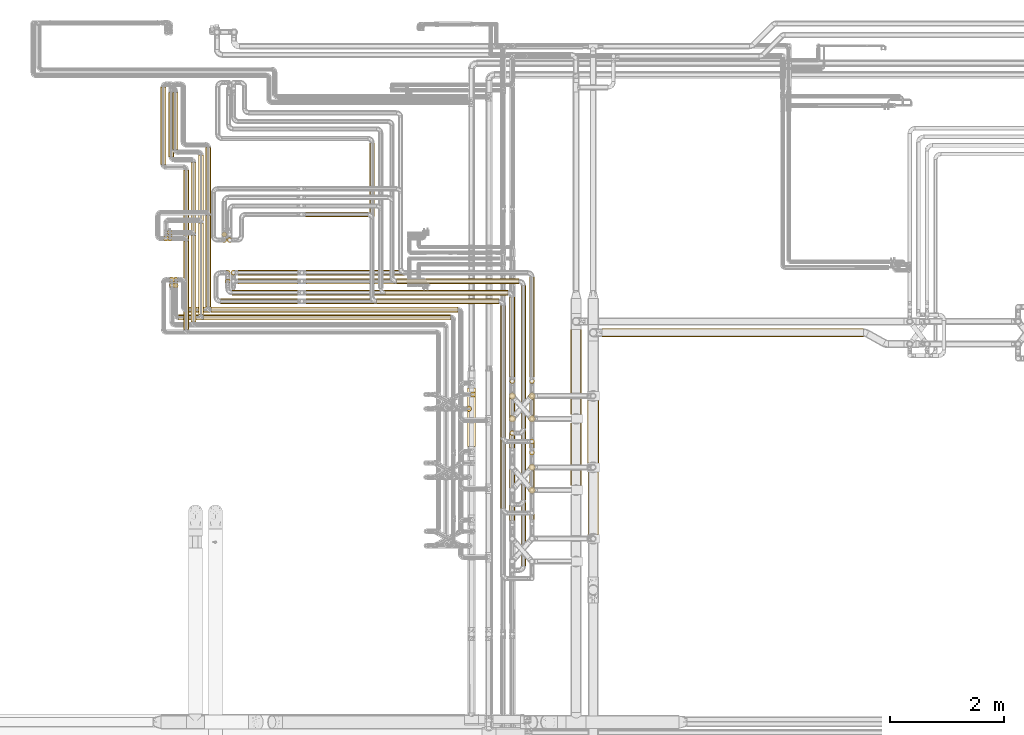
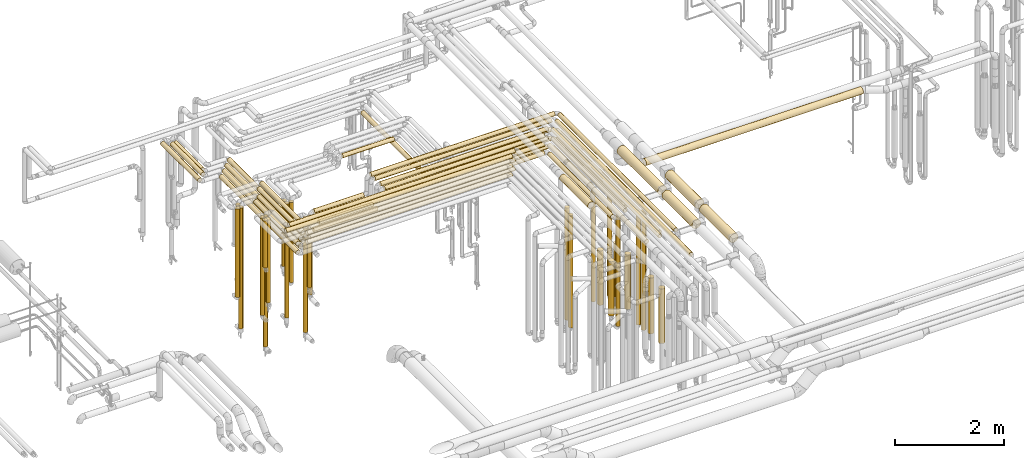
# One storey, part 5 of 824: 76 coverings.
"""IFC2X3 building model written with IfcOpenShell, lengths in millimetres."""

from ifc_helpers import new_model, entity, si_unit, converted_unit, derived_unit, direction, frame, origin, origin_2d_with_axis, place, context, subcontext, project, spatial, polyline, circle, outline, extrude, element, save


model = new_model("IFC2X3")

# Units and contexts
model_context = context("Model", 3, precision=0.01, world=origin(), true_north=direction((6.12303176911189e-17, 1.0)))
body_context = subcontext(model_context, "Body", "Model", "MODEL_VIEW")
ifc_project = project(units=[si_unit("LENGTHUNIT", "METRE", prefix="MILLI"), si_unit("AREAUNIT", "SQUARE_METRE"), si_unit("VOLUMEUNIT", "CUBIC_METRE"), converted_unit("PLANEANGLEUNIT", "DEGREE", entity("IfcRatioMeasure", 0.0174532925199433), si_unit("PLANEANGLEUNIT", "RADIAN"), dimensions=[0, 0, 0, 0, 0, 0, 0]), si_unit("MASSUNIT", "GRAM", prefix="KILO"), derived_unit("MASSDENSITYUNIT", [(si_unit("MASSUNIT", "GRAM", prefix="KILO"), 1), (si_unit("LENGTHUNIT", "METRE"), -3)]), derived_unit("MOMENTOFINERTIAUNIT", [(si_unit("LENGTHUNIT", "METRE"), 4)]), si_unit("TIMEUNIT", "SECOND"), si_unit("FREQUENCYUNIT", "HERTZ"), si_unit("THERMODYNAMICTEMPERATUREUNIT", "DEGREE_CELSIUS"), derived_unit("THERMALTRANSMITTANCEUNIT", [(si_unit("MASSUNIT", "GRAM", prefix="KILO"), 1), (si_unit("THERMODYNAMICTEMPERATUREUNIT", "KELVIN"), -1), (si_unit("TIMEUNIT", "SECOND"), -3)]), derived_unit("VOLUMETRICFLOWRATEUNIT", [(si_unit("LENGTHUNIT", "METRE"), 3), (si_unit("TIMEUNIT", "SECOND"), -1)]), derived_unit("MASSFLOWRATEUNIT", [(si_unit("MASSUNIT", "GRAM", prefix="KILO"), 1), (si_unit("TIMEUNIT", "SECOND"), -1)]), derived_unit("ROTATIONALFREQUENCYUNIT", [(si_unit("TIMEUNIT", "SECOND"), -1)]), si_unit("ELECTRICCURRENTUNIT", "AMPERE"), si_unit("ELECTRICVOLTAGEUNIT", "VOLT"), si_unit("POWERUNIT", "WATT"), si_unit("FORCEUNIT", "NEWTON", prefix="KILO"), si_unit("ILLUMINANCEUNIT", "LUX"), si_unit("LUMINOUSFLUXUNIT", "LUMEN"), si_unit("LUMINOUSINTENSITYUNIT", "CANDELA"), derived_unit("USERDEFINED", [(si_unit("MASSUNIT", "GRAM", prefix="KILO"), -1), (si_unit("LENGTHUNIT", "METRE"), -2), (si_unit("TIMEUNIT", "SECOND"), 3), (si_unit("LUMINOUSFLUXUNIT", "LUMEN"), 1)]), derived_unit("LINEARVELOCITYUNIT", [(si_unit("LENGTHUNIT", "METRE"), 1), (si_unit("TIMEUNIT", "SECOND"), -1)]), si_unit("PRESSUREUNIT", "PASCAL"), derived_unit("USERDEFINED", [(si_unit("LENGTHUNIT", "METRE"), -2), (si_unit("MASSUNIT", "GRAM", prefix="KILO"), 1), (si_unit("TIMEUNIT", "SECOND"), -2)]), derived_unit("LINEARFORCEUNIT", [(si_unit("MASSUNIT", "GRAM", prefix="KILO"), 1), (si_unit("LENGTHUNIT", "METRE"), 1), (si_unit("TIMEUNIT", "SECOND"), -2), (si_unit("LENGTHUNIT", "METRE"), -1)]), derived_unit("PLANARFORCEUNIT", [(si_unit("MASSUNIT", "GRAM", prefix="KILO"), 1), (si_unit("LENGTHUNIT", "METRE"), 1), (si_unit("TIMEUNIT", "SECOND"), -2), (si_unit("LENGTHUNIT", "METRE"), -2)])], contexts=[model_context])

# Site, building, storey
site_placement = place(None, origin())
site = spatial("IfcSite", under=ifc_project, at=site_placement, CompositionType="ELEMENT")
building_placement = place(site_placement, origin())
building = spatial("IfcBuilding", under=site, at=building_placement, CompositionType="ELEMENT")
storey_placement = place(building_placement, frame((0.0, 0.0, 28200.0)))
storey = spatial("IfcBuildingStorey", under=building, at=storey_placement, CompositionType="ELEMENT", Elevation=28200.0)

# Coverings
covering_1_placement = place(storey_placement, frame((31258.78, 14538.0, 3152.25)))
element("IfcCovering", 1, at=covering_1_placement, inside=storey, PredefinedType="INSULATION", context=body_context, shape_type="SweptSolid", body=[
    extrude(circle(Radius=46.15, at=origin_2d_with_axis()), frame((47.75, 0.0, 47.75), z_axis=(0.0, 1.0, 0.0), x_axis=(-1.0, 0.0, 0.0)), (0.0, 0.0, 1.0), 1605.20292594585),
])
covering_2_placement = place(storey_placement, frame((31128.78, 14408.0, 3152.25)))
element("IfcCovering", 2, at=covering_2_placement, inside=storey, PredefinedType="INSULATION", context=body_context, shape_type="SweptSolid", body=[
    extrude(circle(Radius=46.15, at=origin_2d_with_axis()), frame((47.75, 0.0, 47.75), z_axis=(0.0, 1.0, 0.0), x_axis=(-1.0, 0.0, 0.0)), (0.0, 0.0, 1.0), 1605.20292594584),
])
covering_3_placement = place(storey_placement, frame((31354.52, 14442.26, 3152.25)))
element("IfcCovering", 3, at=covering_3_placement, inside=storey, PredefinedType="INSULATION", context=body_context, shape_type="SweptSolid", body=[
    extrude(circle(Radius=46.15, at=origin_2d_with_axis()), frame((0.0, 47.75, 47.75), z_axis=(1.0, 0.0, 0.0), x_axis=(0.0, -1.0, 0.0)), (0.0, 0.0, 1.0), 4327.51165000005),
])
covering_4_placement = place(storey_placement, frame((31224.52, 14312.26, 3152.25)))
element("IfcCovering", 4, at=covering_4_placement, inside=storey, PredefinedType="INSULATION", context=body_context, shape_type="SweptSolid", body=[
    extrude(circle(Radius=46.15, at=origin_2d_with_axis()), frame((0.0, 47.75, 47.75), z_axis=(1.0, 0.0, 0.0), x_axis=(0.0, -1.0, 0.0)), (0.0, 0.0, 1.0), 4327.56910000005),
])
covering_5_placement = place(storey_placement, frame((35847.22, 12092.08, 3479.16)))
element("IfcCovering", 5, at=covering_5_placement, inside=storey, PredefinedType="INSULATION", context=body_context, shape_type="SweptSolid", body=[
    extrude(circle(Radius=69.25, at=origin_2d_with_axis()), frame((70.85, 0.0, 70.85), z_axis=(0.0, 1.0, -9.11558855625522e-08), x_axis=(1.0, 0.0, 0.0)), (0.0, 0.0, 1.0), 1028.00000000001),
])
covering_6_placement = place(storey_placement, frame((30779.54, 14312.26, 3352.25)))
element("IfcCovering", 6, at=covering_6_placement, inside=storey, PredefinedType="INSULATION", context=body_context, shape_type="SweptSolid", body=[
    extrude(circle(Radius=46.15, at=origin_2d_with_axis()), frame((0.0, 47.75, 47.75), z_axis=(1.0, 0.0, 0.0), x_axis=(0.0, -1.0, 0.0)), (0.0, 0.0, 1.0), 4772.54583000002),
])
covering_7_placement = place(storey_placement, frame((30921.54, 14442.26, 3352.25)))
element("IfcCovering", 7, at=covering_7_placement, inside=storey, PredefinedType="INSULATION", context=body_context, shape_type="SweptSolid", body=[
    extrude(circle(Radius=46.15, at=origin_2d_with_axis()), frame((0.0, 47.75, 47.75), z_axis=(1.0, 0.0, 0.0), x_axis=(0.0, -1.0, 0.0)), (0.0, 0.0, 1.0), 4760.48838000002),
])
covering_8_placement = place(storey_placement, frame((30683.55, 14968.46, 455.5)))
element("IfcCovering", 8, at=covering_8_placement, inside=storey, PredefinedType="INSULATION", context=body_context, shape_type="SweptSolid", body=[
    extrude(circle(Radius=46.15, at=origin_2d_with_axis()), frame((47.75, 47.75, 0.0), z_axis=(0.0, 0.0, 1.0), x_axis=(0.0, 1.0, 0.0)), (0.0, 0.0, 1.0), 2896.50000000002),
])
covering_9_placement = place(storey_placement, frame((30683.8, 14868.46, 1500.5)))
element("IfcCovering", 9, at=covering_9_placement, inside=storey, PredefinedType="INSULATION", context=body_context, shape_type="SweptSolid", body=[
    extrude(circle(Radius=46.15, at=origin_2d_with_axis()), frame((47.75, 47.75, 0.0), z_axis=(0.0, 0.0, 1.0), x_axis=(-1.0, 0.0, 0.0)), (0.0, 0.0, 1.0), 1851.50000000002),
])
covering_10_placement = place(storey_placement, frame((30515.78, 15693.46, 1178.45)))
element("IfcCovering", 10, at=covering_10_placement, inside=storey, PredefinedType="INSULATION", context=body_context, shape_type="SweptSolid", body=[
    extrude(circle(Radius=46.15, at=origin_2d_with_axis()), frame((47.75, 47.75, 0.0), z_axis=(0.0, 0.0, 1.0), x_axis=(0.0, 1.0, 0.0)), (0.0, 0.0, 1.0), 1973.5517399999),
])
covering_11_placement = place(storey_placement, frame((30998.78, 14278.0, 3152.25)))
element("IfcCovering", 11, at=covering_11_placement, inside=storey, PredefinedType="INSULATION", context=body_context, shape_type="SweptSolid", body=[
    extrude(circle(Radius=46.15, at=origin_2d_with_axis()), frame((47.75, 0.0, 47.75), z_axis=(0.0, 1.0, 0.0), x_axis=(-1.0, 0.0, 0.0)), (0.0, 0.0, 1.0), 1515.20292594584),
])
covering_12_placement = place(storey_placement, frame((30868.78, 14148.0, 3152.25)))
element("IfcCovering", 12, at=covering_12_placement, inside=storey, PredefinedType="INSULATION", context=body_context, shape_type="SweptSolid", body=[
    extrude(circle(Radius=46.15, at=origin_2d_with_axis()), frame((47.75, 0.0, 47.75), z_axis=(0.0, 1.0, 0.0), x_axis=(-1.0, 0.0, 0.0)), (0.0, 0.0, 1.0), 1545.20292594584),
])
covering_13_placement = place(storey_placement, frame((30622.59, 14868.46, 2298.45)))
element("IfcCovering", 13, at=covering_13_placement, inside=storey, PredefinedType="INSULATION", context=body_context, shape_type="SweptSolid", body=[
    extrude(circle(Radius=46.15, at=origin_2d_with_axis()), frame((47.75, 47.75, 0.0), z_axis=(0.0, 0.0, 1.0), x_axis=(-1.0, 0.0, 0.0)), (0.0, 0.0, 1.0), 1053.55173999999),
])
covering_14_placement = place(storey_placement, frame((30618.78, 14968.46, 1178.45)))
element("IfcCovering", 14, at=covering_14_placement, inside=storey, PredefinedType="INSULATION", context=body_context, shape_type="SweptSolid", body=[
    extrude(circle(Radius=46.15, at=origin_2d_with_axis()), frame((47.75, 47.75, 0.0), z_axis=(0.0, 0.0, 1.0), x_axis=(0.0, 1.0, 0.0)), (0.0, 0.0, 1.0), 2173.55173999987),
])
covering_15_placement = place(storey_placement, frame((30583.78, 15793.46, 1500.5)))
element("IfcCovering", 15, at=covering_15_placement, inside=storey, PredefinedType="INSULATION", context=body_context, shape_type="SweptSolid", body=[
    extrude(circle(Radius=46.15, at=origin_2d_with_axis()), frame((47.75, 47.75, 0.0), z_axis=(0.0, 0.0, 1.0), x_axis=(0.0, -1.0, 0.0)), (0.0, 0.0, 1.0), 1651.50000000004),
])
covering_16_placement = place(storey_placement, frame((30583.78, 15693.46, 455.5)))
element("IfcCovering", 16, at=covering_16_placement, inside=storey, PredefinedType="INSULATION", context=body_context, shape_type="SweptSolid", body=[
    extrude(circle(Radius=46.15, at=origin_2d_with_axis()), frame((47.75, 47.75, 0.0), z_axis=(0.0, 0.0, 1.0), x_axis=(-1.0, 0.0, 0.0)), (0.0, 0.0, 1.0), 2696.50000000011),
])
covering_17_placement = place(storey_placement, frame((30677.33, 17299.2, 2952.25)))
element("IfcCovering", 17, at=covering_17_placement, inside=storey, PredefinedType="INSULATION", context=body_context, shape_type="SweptSolid", body=[
    extrude(circle(Radius=46.15, at=origin_2d_with_axis()), frame((47.75, 0.0, 47.75), z_axis=(0.0, 1.0, 0.0), x_axis=(1.0, 0.0, 0.0)), (0.0, 0.0, 1.0), 993.999999999995),
])
covering_18_placement = place(storey_placement, frame((31128.78, 14408.0, 2952.25)))
element("IfcCovering", 18, at=covering_18_placement, inside=storey, PredefinedType="INSULATION", context=body_context, shape_type="SweptSolid", body=[
    extrude(circle(Radius=46.15, at=origin_2d_with_axis()), frame((47.75, 0.0, 47.75), z_axis=(0.0, 1.0, 0.0), x_axis=(1.0, 0.0, 0.0)), (0.0, 0.0, 1.0), 2795.20292594584),
])
covering_19_placement = place(storey_placement, frame((31224.52, 14312.26, 2952.25)))
element("IfcCovering", 19, at=covering_19_placement, inside=storey, PredefinedType="INSULATION", context=body_context, shape_type="SweptSolid", body=[
    extrude(circle(Radius=46.15, at=origin_2d_with_axis()), frame((0.0, 47.75, 47.75), z_axis=(1.0, 0.0, 0.0), x_axis=(0.0, 1.0, 0.0)), (0.0, 0.0, 1.0), 4327.56910000003),
])
covering_20_placement = place(storey_placement, frame((30609.3, 17169.2, 2952.25)))
element("IfcCovering", 20, at=covering_20_placement, inside=storey, PredefinedType="INSULATION", context=body_context, shape_type="SweptSolid", body=[
    extrude(circle(Radius=46.15, at=origin_2d_with_axis()), frame((47.75, 0.0, 47.75), z_axis=(0.0, 1.0, 0.0), x_axis=(-1.0, 0.0, 0.0)), (0.0, 0.0, 1.0), 1124.0),
])
covering_21_placement = place(storey_placement, frame((30998.78, 14278.0, 2952.25)))
element("IfcCovering", 21, at=covering_21_placement, inside=storey, PredefinedType="INSULATION", context=body_context, shape_type="SweptSolid", body=[
    extrude(circle(Radius=46.15, at=origin_2d_with_axis()), frame((47.75, 0.0, 47.75), z_axis=(0.0, 1.0, 0.0), x_axis=(1.0, 0.0, 0.0)), (0.0, 0.0, 1.0), 2795.20292594584),
])
covering_22_placement = place(storey_placement, frame((35826.04, 12708.42, 448.0)))
element("IfcCovering", 22, at=covering_22_placement, inside=storey, PredefinedType="INSULATION", context=body_context, shape_type="SweptSolid", body=[
    extrude(circle(Radius=46.15, at=origin_2d_with_axis()), frame((47.75, 47.75, 0.0), z_axis=(0.0, 0.0, 1.0), x_axis=(-1.0, 0.0, 0.0)), (0.0, 0.0, 1.0), 2504.0),
])
covering_23_placement = place(storey_placement, frame((31354.52, 14442.26, 2952.25)))
element("IfcCovering", 23, at=covering_23_placement, inside=storey, PredefinedType="INSULATION", context=body_context, shape_type="SweptSolid", body=[
    extrude(circle(Radius=46.15, at=origin_2d_with_axis()), frame((0.0, 47.75, 47.75), z_axis=(1.0, 0.0, 0.0), x_axis=(0.0, 1.0, 0.0)), (0.0, 0.0, 1.0), 4327.51165000003),
])
covering_24_placement = place(storey_placement, frame((31258.78, 14538.0, 2952.25)))
element("IfcCovering", 24, at=covering_24_placement, inside=storey, PredefinedType="INSULATION", context=body_context, shape_type="SweptSolid", body=[
    extrude(circle(Radius=46.15, at=origin_2d_with_axis()), frame((47.75, 0.0, 47.75), z_axis=(0.0, 1.0, 0.0), x_axis=(-1.0, 0.0, 0.0)), (0.0, 0.0, 1.0), 2795.20292594584),
])
covering_25_placement = place(storey_placement, frame((35895.3, 12958.46, 448.0)))
element("IfcCovering", 25, at=covering_25_placement, inside=storey, PredefinedType="INSULATION", context=body_context, shape_type="SweptSolid", body=[
    extrude(circle(Radius=46.15, at=origin_2d_with_axis()), frame((47.75, 47.75, 0.0), z_axis=(0.0, 0.0, 1.0), x_axis=(-1.0, 0.0, 0.0)), (0.0, 0.0, 1.0), 2504.0),
])
covering_26_placement = place(storey_placement, frame((30467.3, 17039.2, 2952.25)))
element("IfcCovering", 26, at=covering_26_placement, inside=storey, PredefinedType="INSULATION", context=body_context, shape_type="SweptSolid", body=[
    extrude(circle(Radius=46.15, at=origin_2d_with_axis()), frame((47.75, 0.0, 47.75), z_axis=(0.0, 1.0, 0.0), x_axis=(-1.0, 0.0, 0.0)), (0.0, 0.0, 1.0), 1353.99999995382),
])
covering_27_placement = place(storey_placement, frame((30868.78, 14148.0, 2952.25)))
element("IfcCovering", 27, at=covering_27_placement, inside=storey, PredefinedType="INSULATION", context=body_context, shape_type="SweptSolid", body=[
    extrude(circle(Radius=46.15, at=origin_2d_with_axis()), frame((47.75, 0.0, 47.75), z_axis=(0.0, 1.0, 0.0), x_axis=(1.0, 0.0, 0.0)), (0.0, 0.0, 1.0), 2795.20292594584),
])
covering_28_placement = place(storey_placement, frame((34128.44, 14716.0, 2953.4)))
element("IfcCovering", 28, at=covering_28_placement, inside=storey, PredefinedType="INSULATION", context=body_context, shape_type="SweptSolid", body=[
    extrude(circle(Radius=45.0, at=origin_2d_with_axis()), frame((46.6, 0.0, 46.6), z_axis=(0.0, 1.0, 0.0), x_axis=(-1.0, 0.0, 0.0)), (0.0, 0.0, 1.0), 2699.20292594585),
])
covering_29_placement = place(storey_placement, frame((34251.03, 14593.41, 2953.4)))
element("IfcCovering", 29, at=covering_29_placement, inside=storey, PredefinedType="INSULATION", context=body_context, shape_type="SweptSolid", body=[
    extrude(circle(Radius=45.0, at=origin_2d_with_axis()), frame((0.0, 46.6, 46.6), z_axis=(1.0, 0.0, 0.0), x_axis=(0.0, 1.0, 0.0)), (0.0, 0.0, 1.0), 2143.00000000003),
])
covering_30_placement = place(storey_placement, frame((36423.44, 12257.17, 2953.4)))
element("IfcCovering", 30, at=covering_30_placement, inside=storey, PredefinedType="INSULATION", context=body_context, shape_type="SweptSolid", body=[
    extrude(circle(Radius=45.0, at=origin_2d_with_axis()), frame((46.6, 0.0, 46.6), z_axis=(0.0, 1.0, 0.0), x_axis=(-1.0, 0.0, 0.0)), (0.0, 0.0, 1.0), 2306.8258040542),
])
covering_31_placement = place(storey_placement, frame((36928.44, 12134.58, 476.0)))
element("IfcCovering", 31, at=covering_31_placement, inside=storey, PredefinedType="INSULATION", context=body_context, shape_type="SweptSolid", body=[
    extrude(outline(polyline([(-5.87, -44.62), (5.87, -44.62), (17.22, -41.57), (27.39, -35.7), (35.7, -27.39), (41.57, -17.22), (44.62, -5.87), (44.62, 5.87), (41.57, 17.22), (35.7, 27.39), (27.39, 35.7), (17.22, 41.57), (5.87, 44.62), (-5.87, 44.62), (-17.22, 41.57), (-27.39, 35.7), (-35.7, 27.39), (-41.57, 17.22), (-44.62, 5.87), (-44.62, -5.87), (-41.57, -17.22), (-35.7, -27.39), (-27.39, -35.7), (-17.22, -41.57), (-5.87, -44.62)])), frame((46.6, 46.6, 0.0), z_axis=(-3.67749217620578e-09, 0.0, 1.0), x_axis=(-0.130526192220067, 0.991444861373808, 0.0)), (0.0, 0.0, 1.0), 2447.99999099997),
])
covering_32_placement = place(storey_placement, frame((34402.66, 14743.41, 2953.4)))
element("IfcCovering", 32, at=covering_32_placement, inside=storey, PredefinedType="INSULATION", context=body_context, shape_type="SweptSolid", body=[
    extrude(circle(Radius=45.0, at=origin_2d_with_axis()), frame((0.0, 46.6, 46.6), z_axis=(1.0, 0.0, 0.0), x_axis=(0.0, 1.0, 0.0)), (0.0, 0.0, 1.0), 2150.98068574385),
])
covering_33_placement = place(storey_placement, frame((36583.05, 13316.2, 2953.4)))
element("IfcCovering", 33, at=covering_33_placement, inside=storey, PredefinedType="INSULATION", context=body_context, shape_type="SweptSolid", body=[
    extrude(circle(Radius=45.0, at=origin_2d_with_axis()), frame((46.6, 0.0, 46.6), z_axis=(0.0, 1.0, 0.0), x_axis=(1.0, 0.0, 0.0)), (0.0, 0.0, 1.0), 1397.79727405418),
])
covering_34_placement = place(storey_placement, frame((36583.05, 13193.61, 476.0)))
element("IfcCovering", 34, at=covering_34_placement, inside=storey, PredefinedType="INSULATION", context=body_context, shape_type="SweptSolid", body=[
    extrude(circle(Radius=45.0, at=origin_2d_with_axis()), frame((46.6, 46.6, 0.0)), (0.0, 0.0, 1.0), 2447.99999999999),
])
covering_35_placement = place(storey_placement, frame((34251.03, 14593.41, 3153.4)))
element("IfcCovering", 35, at=covering_35_placement, inside=storey, PredefinedType="INSULATION", context=body_context, shape_type="SweptSolid", body=[
    extrude(circle(Radius=45.0, at=origin_2d_with_axis()), frame((0.0, 46.6, 46.6), z_axis=(1.0, 0.0, 0.0), x_axis=(0.0, 1.0, 0.0)), (0.0, 0.0, 1.0), 2143.00000000005),
])
covering_36_placement = place(storey_placement, frame((34402.66, 14743.41, 3153.4)))
element("IfcCovering", 36, at=covering_36_placement, inside=storey, PredefinedType="INSULATION", context=body_context, shape_type="SweptSolid", body=[
    extrude(circle(Radius=45.0, at=origin_2d_with_axis()), frame((0.0, 46.6, 46.6), z_axis=(1.0, 0.0, 0.0), x_axis=(0.0, 1.0, 0.0)), (0.0, 0.0, 1.0), 2150.98068574388),
])
covering_37_placement = place(storey_placement, frame((33021.03, 14593.41, 3353.4)))
element("IfcCovering", 37, at=covering_37_placement, inside=storey, PredefinedType="INSULATION", context=body_context, shape_type="SweptSolid", body=[
    extrude(circle(Radius=45.0, at=origin_2d_with_axis()), frame((0.0, 46.6, 46.6), z_axis=(1.0, 0.0, 0.0), x_axis=(0.0, -1.0, 0.0)), (0.0, 0.0, 1.0), 3373.00000900002),
])
covering_38_placement = place(storey_placement, frame((33021.03, 14743.41, 3353.4)))
element("IfcCovering", 38, at=covering_38_placement, inside=storey, PredefinedType="INSULATION", context=body_context, shape_type="SweptSolid", body=[
    extrude(circle(Radius=45.0, at=origin_2d_with_axis()), frame((0.0, 46.6, 46.6), z_axis=(1.0, 0.0, 0.0), x_axis=(0.0, -1.0, 0.0)), (0.0, 0.0, 1.0), 3532.61017471227),
])
covering_39_placement = place(storey_placement, frame((36423.44, 11007.17, 3153.4)))
element("IfcCovering", 39, at=covering_39_placement, inside=storey, PredefinedType="INSULATION", context=body_context, shape_type="SweptSolid", body=[
    extrude(circle(Radius=45.0, at=origin_2d_with_axis()), frame((46.6, 0.0, 46.6), z_axis=(0.0, 1.0, 0.0), x_axis=(-1.0, 0.0, 0.0)), (0.0, 0.0, 1.0), 3556.82579505427),
])
covering_40_placement = place(storey_placement, frame((36583.05, 12066.2, 3153.4)))
element("IfcCovering", 40, at=covering_40_placement, inside=storey, PredefinedType="INSULATION", context=body_context, shape_type="SweptSolid", body=[
    extrude(circle(Radius=45.0, at=origin_2d_with_axis()), frame((46.6, 0.0, 46.6), z_axis=(0.0, 1.0, 0.0), x_axis=(1.0, 0.0, 0.0)), (0.0, 0.0, 1.0), 2647.79726505419),
])
covering_41_placement = place(storey_placement, frame((36583.05, 10795.72, 3353.4)))
element("IfcCovering", 41, at=covering_41_placement, inside=storey, PredefinedType="INSULATION", context=body_context, shape_type="SweptSolid", body=[
    extrude(circle(Radius=45.0, at=origin_2d_with_axis()), frame((46.6, 0.0, 46.6), z_axis=(0.0, 1.0, 0.0), x_axis=(-1.0, 0.0, 0.0)), (0.0, 0.0, 1.0), 3918.27777979508),
])
covering_42_placement = place(storey_placement, frame((31517.75, 14593.41, 2953.4)))
element("IfcCovering", 42, at=covering_42_placement, inside=storey, PredefinedType="INSULATION", context=body_context, shape_type="SweptSolid", body=[
    extrude(circle(Radius=45.0, at=origin_2d_with_axis()), frame((0.0, 46.6, 46.6), z_axis=(1.0, 0.0, 0.0), x_axis=(0.0, -1.0, 0.0)), (0.0, 0.0, 1.0), 1351.28244),
])
covering_43_placement = place(storey_placement, frame((31722.75, 14743.41, 2953.4)))
element("IfcCovering", 43, at=covering_43_placement, inside=storey, PredefinedType="INSULATION", context=body_context, shape_type="SweptSolid", body=[
    extrude(circle(Radius=45.0, at=origin_2d_with_axis()), frame((0.0, 46.6, 46.6), z_axis=(1.0, 0.0, 0.0), x_axis=(0.0, 1.0, 0.0)), (0.0, 0.0, 1.0), 1146.28244),
])
covering_44_placement = place(storey_placement, frame((31600.16, 15092.41, 379.5)))
element("IfcCovering", 44, at=covering_44_placement, inside=storey, PredefinedType="INSULATION", context=body_context, shape_type="SweptSolid", body=[
    extrude(circle(Radius=45.0, at=origin_2d_with_axis()), frame((46.6, 46.6, 0.0), z_axis=(0.0, 0.0, 1.0), x_axis=(0.0, -1.0, 0.0)), (0.0, 0.0, 1.0), 2544.50000000001),
])
covering_45_placement = place(storey_placement, frame((31600.16, 14942.41, 1469.5)))
element("IfcCovering", 45, at=covering_45_placement, inside=storey, PredefinedType="INSULATION", context=body_context, shape_type="SweptSolid", body=[
    extrude(circle(Radius=45.0, at=origin_2d_with_axis()), frame((46.6, 46.6, 0.0), z_axis=(0.0, 0.0, 1.0), x_axis=(-1.0, 0.0, 0.0)), (0.0, 0.0, 1.0), 1454.50000000002),
])
covering_46_placement = place(storey_placement, frame((33011.03, 16114.61, 3153.4)))
element("IfcCovering", 46, at=covering_46_placement, inside=storey, PredefinedType="INSULATION", context=body_context, shape_type="SweptSolid", body=[
    extrude(circle(Radius=45.0, at=origin_2d_with_axis()), frame((0.0, 46.6, 46.6), z_axis=(1.0, 0.0, 0.0), x_axis=(0.0, -1.0, 0.0)), (0.0, 0.0, 1.0), 1088.00000000002),
])
covering_47_placement = place(storey_placement, frame((31633.66, 15664.61, 1136.0)))
element("IfcCovering", 47, at=covering_47_placement, inside=storey, PredefinedType="INSULATION", context=body_context, shape_type="SweptSolid", body=[
    extrude(circle(Radius=45.0, at=origin_2d_with_axis()), frame((46.6, 46.6, 0.0), z_axis=(0.0, 0.0, 1.0), x_axis=(0.0, 1.0, 0.0)), (0.0, 0.0, 1.0), 1788.00000000001),
])
covering_48_placement = place(storey_placement, frame((36914.19, 11269.36, 589.0)))
element("IfcCovering", 48, at=covering_48_placement, inside=storey, PredefinedType="INSULATION", context=body_context, shape_type="SweptSolid", body=[
    extrude(circle(Radius=59.25, at=origin_2d_with_axis()), frame((60.85, 60.85, 0.0), z_axis=(0.0, 0.0, 1.0), x_axis=(0.0, -1.0, 0.0)), (0.0, 0.0, 1.0), 1222.00000649532),
])
covering_49_placement = place(storey_placement, frame((36914.19, 12520.33, 589.0)))
element("IfcCovering", 49, at=covering_49_placement, inside=storey, PredefinedType="INSULATION", context=body_context, shape_type="SweptSolid", body=[
    extrude(circle(Radius=59.25, at=origin_2d_with_axis()), frame((60.85, 60.85, 0.0), z_axis=(0.0, 0.0, 1.0), x_axis=(0.0, 1.0, 0.0)), (0.0, 0.0, 1.0), 1222.00000649531),
])
covering_50_placement = place(storey_placement, frame((36568.8, 12919.36, 565.0)))
element("IfcCovering", 50, at=covering_50_placement, inside=storey, PredefinedType="INSULATION", context=body_context, shape_type="SweptSolid", body=[
    extrude(circle(Radius=59.25, at=origin_2d_with_axis()), frame((60.85, 60.85, 0.0), z_axis=(0.0, 0.0, 1.0), x_axis=(0.0, 1.0, 0.0)), (0.0, 0.0, 1.0), 1216.00000000001),
])
covering_51_placement = place(storey_placement, frame((38200.3, 14015.32, 2426.4)))
element("IfcCovering", 51, at=covering_51_placement, inside=storey, PredefinedType="INSULATION", context=body_context, shape_type="SweptSolid", body=[
    extrude(circle(Radius=72.0, at=origin_2d_with_axis()), frame((0.0, 73.6, 73.6), z_axis=(1.0, 0.0, 0.0), x_axis=(0.0, -1.0, 0.0)), (0.0, 0.0, 1.0), 4582.2791782302),
])
covering_52_placement = place(storey_placement, frame((36928.44, 13316.2, 2953.4)))
element("IfcCovering", 52, at=covering_52_placement, inside=storey, PredefinedType="INSULATION", context=body_context, shape_type="SweptSolid", body=[
    extrude(circle(Radius=45.0, at=origin_2d_with_axis()), frame((46.6, 0.0, 46.6), z_axis=(0.0, 1.0, 0.0), x_axis=(-1.0, 0.0, 0.0)), (0.0, 0.0, 1.0), 1746.7974740542),
])
covering_53_placement = place(storey_placement, frame((34601.03, 14942.41, 2953.4)))
element("IfcCovering", 53, at=covering_53_placement, inside=storey, PredefinedType="INSULATION", context=body_context, shape_type="SweptSolid", body=[
    extrude(circle(Radius=45.0, at=origin_2d_with_axis()), frame((0.0, 46.6, 46.6), z_axis=(1.0, 0.0, 0.0), x_axis=(0.0, 1.0, 0.0)), (0.0, 0.0, 1.0), 2148.00000000001),
])
covering_54_placement = place(storey_placement, frame((36778.44, 12407.17, 2953.4)))
element("IfcCovering", 54, at=covering_54_placement, inside=storey, PredefinedType="INSULATION", context=body_context, shape_type="SweptSolid", body=[
    extrude(circle(Radius=45.0, at=origin_2d_with_axis()), frame((46.6, 0.0, 46.6), z_axis=(0.0, 1.0, 0.0), x_axis=(1.0, 0.0, 0.0)), (0.0, 0.0, 1.0), 2505.82601323927),
])
covering_55_placement = place(storey_placement, frame((36928.44, 13193.61, 476.0)))
element("IfcCovering", 55, at=covering_55_placement, inside=storey, PredefinedType="INSULATION", context=body_context, shape_type="SweptSolid", body=[
    extrude(circle(Radius=45.0, at=origin_2d_with_axis()), frame((46.6, 46.6, 0.0)), (0.0, 0.0, 1.0), 2448.0),
])
covering_56_placement = place(storey_placement, frame((36583.05, 12284.58, 476.0)))
element("IfcCovering", 56, at=covering_56_placement, inside=storey, PredefinedType="INSULATION", context=body_context, shape_type="SweptSolid", body=[
    extrude(circle(Radius=45.0, at=origin_2d_with_axis()), frame((46.6, 46.6, 0.0), z_axis=(0.0, 0.0, 1.0), x_axis=(0.0, -1.0, 0.0)), (0.0, 0.0, 1.0), 2447.99999099998),
])
covering_57_placement = place(storey_placement, frame((34601.03, 14942.41, 3153.4)))
element("IfcCovering", 57, at=covering_57_placement, inside=storey, PredefinedType="INSULATION", context=body_context, shape_type="SweptSolid", body=[
    extrude(circle(Radius=45.0, at=origin_2d_with_axis()), frame((0.0, 46.6, 46.6), z_axis=(1.0, 0.0, 0.0), x_axis=(0.0, 1.0, 0.0)), (0.0, 0.0, 1.0), 2148.00000000003),
])
covering_58_placement = place(storey_placement, frame((33021.03, 15093.41, 3353.4)))
element("IfcCovering", 58, at=covering_58_placement, inside=storey, PredefinedType="INSULATION", context=body_context, shape_type="SweptSolid", body=[
    extrude(circle(Radius=45.0, at=origin_2d_with_axis()), frame((0.0, 46.6, 46.6), z_axis=(1.0, 0.0, 0.0), x_axis=(0.0, -1.0, 0.0)), (0.0, 0.0, 1.0), 3878.00000000002),
])
covering_59_placement = place(storey_placement, frame((33021.03, 14943.41, 3353.4)))
element("IfcCovering", 59, at=covering_59_placement, inside=storey, PredefinedType="INSULATION", context=body_context, shape_type="SweptSolid", body=[
    extrude(circle(Radius=45.0, at=origin_2d_with_axis()), frame((0.0, 46.6, 46.6), z_axis=(1.0, 0.0, 0.0), x_axis=(0.0, -1.0, 0.0)), (0.0, 0.0, 1.0), 3728.00000000001),
])
covering_60_placement = place(storey_placement, frame((36928.44, 12066.2, 3153.4)))
element("IfcCovering", 60, at=covering_60_placement, inside=storey, PredefinedType="INSULATION", context=body_context, shape_type="SweptSolid", body=[
    extrude(circle(Radius=45.0, at=origin_2d_with_axis()), frame((46.6, 0.0, 46.6), z_axis=(0.0, 1.0, 0.0), x_axis=(-1.0, 0.0, 0.0)), (0.0, 0.0, 1.0), 2996.79746505423),
])
covering_61_placement = place(storey_placement, frame((36778.44, 11157.17, 3153.4)))
element("IfcCovering", 61, at=covering_61_placement, inside=storey, PredefinedType="INSULATION", context=body_context, shape_type="SweptSolid", body=[
    extrude(circle(Radius=45.0, at=origin_2d_with_axis()), frame((46.6, 0.0, 46.6), z_axis=(0.0, 1.0, 0.0), x_axis=(-1.0, 0.0, 0.0)), (0.0, 0.0, 1.0), 3755.82600423931),
])
covering_62_placement = place(storey_placement, frame((36928.44, 10816.2, 3353.4)))
element("IfcCovering", 62, at=covering_62_placement, inside=storey, PredefinedType="INSULATION", context=body_context, shape_type="SweptSolid", body=[
    extrude(circle(Radius=45.0, at=origin_2d_with_axis()), frame((46.6, 0.0, 46.6), z_axis=(0.0, 1.0, 0.0), x_axis=(-1.0, 0.0, 0.0)), (0.0, 0.0, 1.0), 4247.79746505422),
])
covering_63_placement = place(storey_placement, frame((36778.44, 10002.17, 3353.4)))
element("IfcCovering", 63, at=covering_63_placement, inside=storey, PredefinedType="INSULATION", context=body_context, shape_type="SweptSolid", body=[
    extrude(circle(Radius=45.0, at=origin_2d_with_axis()), frame((46.6, 0.0, 46.6), z_axis=(0.0, 1.0, 0.0), x_axis=(1.0, 0.0, 0.0)), (0.0, 0.0, 1.0), 4911.82600423926),
])
covering_64_placement = place(storey_placement, frame((36928.44, 11943.61, 476.0)))
element("IfcCovering", 64, at=covering_64_placement, inside=storey, PredefinedType="INSULATION", context=body_context, shape_type="SweptSolid", body=[
    extrude(circle(Radius=45.0, at=origin_2d_with_axis()), frame((46.6, 46.6, 0.0)), (0.0, 0.0, 1.0), 2648.0),
])
covering_65_placement = place(storey_placement, frame((36914.19, 11669.36, 565.0)))
element("IfcCovering", 65, at=covering_65_placement, inside=storey, PredefinedType="INSULATION", context=body_context, shape_type="SweptSolid", body=[
    extrude(circle(Radius=59.25, at=origin_2d_with_axis()), frame((60.85, 60.85, 0.0)), (0.0, 0.0, 1.0), 1246.0),
])
covering_66_placement = place(storey_placement, frame((37952.2, 10557.7, 2903.9)))
element("IfcCovering", 66, at=covering_66_placement, inside=storey, PredefinedType="INSULATION", context=body_context, shape_type="SweptSolid", body=[
    extrude(circle(Radius=94.5, at=origin_2d_with_axis()), frame((96.1, 0.0, 96.1), z_axis=(0.0, 1.0, 0.0), x_axis=(1.0, 0.0, 0.0)), (0.0, 0.0, 1.0), 1095.00000000002),
])
covering_67_placement = place(storey_placement, frame((37949.2, 11807.7, 2900.9)))
element("IfcCovering", 67, at=covering_67_placement, inside=storey, PredefinedType="INSULATION", context=body_context, shape_type="SweptSolid", body=[
    extrude(circle(Radius=97.5, at=origin_2d_with_axis()), frame((99.1, 0.0, 99.1), z_axis=(0.0, 1.0, 0.0), x_axis=(1.0, 0.0, 0.0)), (0.0, 0.0, 1.0), 1094.43742839127),
])
covering_68_placement = place(storey_placement, frame((31821.03, 15093.41, 2953.4)))
element("IfcCovering", 68, at=covering_68_placement, inside=storey, PredefinedType="INSULATION", context=body_context, shape_type="SweptSolid", body=[
    extrude(circle(Radius=45.0, at=origin_2d_with_axis()), frame((0.0, 46.6, 46.6), z_axis=(1.0, 0.0, 0.0), x_axis=(0.0, -1.0, 0.0)), (0.0, 0.0, 1.0), 1048.00000000002),
])
covering_69_placement = place(storey_placement, frame((31821.03, 14943.41, 2953.4)))
element("IfcCovering", 69, at=covering_69_placement, inside=storey, PredefinedType="INSULATION", context=body_context, shape_type="SweptSolid", body=[
    extrude(circle(Radius=45.0, at=origin_2d_with_axis()), frame((0.0, 46.6, 46.6), z_axis=(1.0, 0.0, 0.0), x_axis=(0.0, -1.0, 0.0)), (0.0, 0.0, 1.0), 1048.00000000003),
])
covering_70_placement = place(storey_placement, frame((31537.66, 15664.61, 379.5)))
element("IfcCovering", 70, at=covering_70_placement, inside=storey, PredefinedType="INSULATION", context=body_context, shape_type="SweptSolid", body=[
    extrude(circle(Radius=45.0, at=origin_2d_with_axis()), frame((46.6, 46.6, 0.0), z_axis=(0.0, 0.0, 1.0), x_axis=(0.0, -1.0, 0.0)), (0.0, 0.0, 1.0), 2544.50000000001),
])
covering_71_placement = place(storey_placement, frame((31537.66, 15764.61, 1469.5)))
element("IfcCovering", 71, at=covering_71_placement, inside=storey, PredefinedType="INSULATION", context=body_context, shape_type="SweptSolid", body=[
    extrude(circle(Radius=45.0, at=origin_2d_with_axis()), frame((46.6, 46.6, 0.0), z_axis=(0.0, 0.0, 1.0), x_axis=(-1.0, 0.0, 0.0)), (0.0, 0.0, 1.0), 1454.50000000001),
])
covering_72_placement = place(storey_placement, frame((36914.19, 12918.8, 629.0)))
element("IfcCovering", 72, at=covering_72_placement, inside=storey, PredefinedType="INSULATION", context=body_context, shape_type="SweptSolid", body=[
    extrude(circle(Radius=59.25, at=origin_2d_with_axis()), frame((60.85, 60.85, 0.0), z_axis=(0.0, 0.0, 1.0), x_axis=(0.0, -1.0, 0.0)), (0.0, 0.0, 1.0), 1182.0),
])
covering_73_placement = place(storey_placement, frame((36568.83, 12520.33, 564.99)))
element("IfcCovering", 73, at=covering_73_placement, inside=storey, PredefinedType="INSULATION", context=body_context, shape_type="SweptSolid", body=[
    extrude(circle(Radius=59.25, at=origin_2d_with_axis()), frame((60.85, 60.85, 0.01), z_axis=(0.000201513087669316, 0.0, 0.999999979696238), x_axis=(0.999999979696238, 0.0, -0.000201513087669316)), (0.0, 0.0, 1.0), 1216.00001903948),
])
covering_74_placement = place(storey_placement, frame((31698.44, 15093.41, 1186.0)))
element("IfcCovering", 74, at=covering_74_placement, inside=storey, PredefinedType="INSULATION", context=body_context, shape_type="SweptSolid", body=[
    extrude(circle(Radius=45.0, at=origin_2d_with_axis()), frame((46.6, 46.6, 0.0), z_axis=(0.0, 0.0, 1.0), x_axis=(0.0, 1.0, 0.0)), (0.0, 0.0, 1.0), 1738.00000000001),
])
covering_75_placement = place(storey_placement, frame((37652.2, 12658.67, 2803.81)))
element("IfcCovering", 75, at=covering_75_placement, inside=storey, PredefinedType="INSULATION", context=body_context, shape_type="SweptSolid", body=[
    extrude(circle(Radius=94.5, at=origin_2d_with_axis()), frame((96.1, 0.0, 96.1), z_axis=(0.0, 1.0, -7.18992411449206e-07), x_axis=(-1.0, 0.0, 0.0)), (0.0, 0.0, 1.0), 1484.94897976168),
])
covering_76_placement = place(storey_placement, frame((37652.2, 11407.7, 2803.81)))
element("IfcCovering", 76, at=covering_76_placement, inside=storey, PredefinedType="INSULATION", context=body_context, shape_type="SweptSolid", body=[
    extrude(circle(Radius=94.5, at=origin_2d_with_axis()), frame((96.1, 0.0, 96.1), z_axis=(0.0, 1.0, -7.18992411449206e-07), x_axis=(-1.0, 0.0, 0.0)), (0.0, 0.0, 1.0), 1095.97124281503),
])

save(model, "model.ifc")
